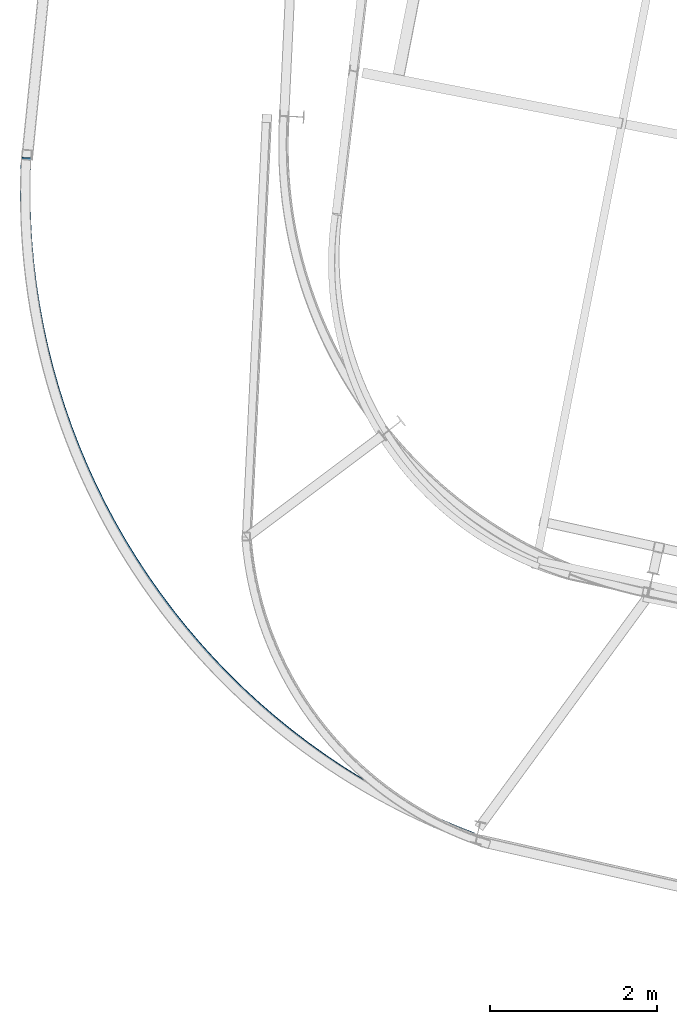
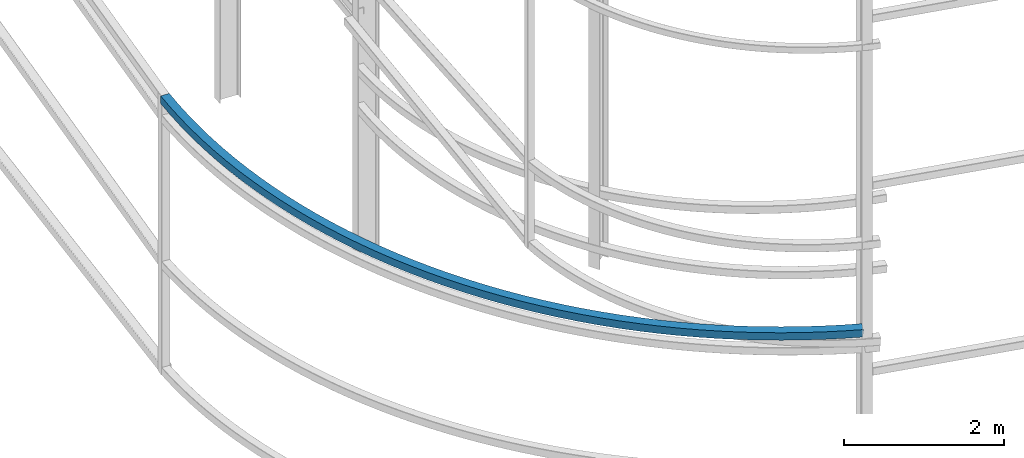
# One storey, part 208 of 215: 1 beam, 1 element without a shape of its own.
"""IFC2X3 building model written with IfcOpenShell, lengths in millimetres."""

import ifcopenshell
import ifcopenshell.guid

model = None  # the IFC model being written
_history = None  # IfcOwnerHistory: only IFC2X3 demands one
_inside = {}  # id of a spatial element -> (the spatial element, [elements in it])
_under = {}  # id of a project, library or spatial element -> (it, [spatial elements below it])
_declared = {}  # id of a project -> (the project, [libraries it declares])
_typed = {}  # id of a type object -> (the type object, [elements of that type])
_made_of = {}  # id of a material, layer set ... -> (it, [elements and type objects made of it])


def new_model(schema):
    """Start an empty IFC model of exactly this schema.

    Asked for "IFC4X3", IfcOpenShell would pick the latest addendum, in which some entities
    have other attributes; the version numbers below select the first issue.
    IFC2X3 requires an IfcOwnerHistory on every rooted entity: one is made here for all.
    """
    global model, _history
    if schema == "IFC4X3":
        model = ifcopenshell.file(schema_version=(4, 3, 0, 0))
    else:
        model = ifcopenshell.file(schema=schema)
    _inside.clear()
    _under.clear()
    _declared.clear()
    _typed.clear()
    _made_of.clear()
    _history = None
    if model.schema == "IFC2X3":
        org = make("IfcOrganization", Name="unknown")
        user = make(
            "IfcPersonAndOrganization",
            ThePerson=make("IfcPerson", FamilyName="unknown"),
            TheOrganization=org,
        )
        app = make(
            "IfcApplication",
            ApplicationDeveloper=org,
            Version="unknown",
            ApplicationFullName="unknown",
            ApplicationIdentifier="unknown",
        )
        _history = make(
            "IfcOwnerHistory",
            OwningUser=user,
            OwningApplication=app,
            ChangeAction="ADDED",
            CreationDate=0,
        )
    return model


def make(cls, **values):
    """One entity of the class cls with the attributes given. An attribute that is None is left unset."""
    return model.create_entity(
        cls, **{name: value for name, value in values.items() if value is not None}
    )


def rooted(cls, **values):
    """An entity with a GlobalId (a new one), such as an element, a storey or a relation."""
    return make(cls, GlobalId=ifcopenshell.guid.new(), OwnerHistory=_history, **values)


def si_unit(unit_type, name, prefix=None):
    """IfcSIUnit, for example si_unit("LENGTHUNIT", "METRE", prefix="MILLI")."""
    return make("IfcSIUnit", UnitType=unit_type, Prefix=prefix, Name=name)


def assignment(units):
    """IfcUnitAssignment: the units of a project."""
    return None if units is None else make("IfcUnitAssignment", Units=units)


def point(xyz):
    """IfcCartesianPoint."""
    return None if xyz is None else make("IfcCartesianPoint", Coordinates=xyz)


def direction(xyz):
    """IfcDirection."""
    return None if xyz is None else make("IfcDirection", DirectionRatios=xyz)


def frame(location, z_axis=None, x_axis=None):
    """IfcAxis2Placement3D, a coordinate frame: its origin and axes. An axis left out is left unset."""
    return make(
        "IfcAxis2Placement3D",
        Location=point(location),
        Axis=direction(z_axis),
        RefDirection=direction(x_axis),
    )


def origin_with_axes():
    """The frame at (0, 0, 0) with the z axis (0, 0, 1) and the x axis (1, 0, 0) written out."""
    return frame((0.0, 0.0, 0.0), z_axis=(0.0, 0.0, 1.0), x_axis=(1.0, 0.0, 0.0))


def place(relative_to, where):
    """IfcLocalPlacement: puts the frame where relative to a parent placement (None: the world)."""
    return make(
        "IfcLocalPlacement", PlacementRelTo=relative_to, RelativePlacement=where
    )


def context(
    kind, dimensions, precision=None, world=None, true_north=None, identifier=None
):
    """IfcGeometricRepresentationContext, for example the 3D "Model" context."""
    return make(
        "IfcGeometricRepresentationContext",
        ContextIdentifier=identifier,
        ContextType=kind,
        CoordinateSpaceDimension=dimensions,
        Precision=precision,
        WorldCoordinateSystem=world,
        TrueNorth=true_north,
    )


def subcontext(parent, identifier, kind, view, scale=None):
    """IfcGeometricRepresentationSubContext, for example "Body" below "Model"."""
    return make(
        "IfcGeometricRepresentationSubContext",
        ContextIdentifier=identifier,
        ContextType=kind,
        ParentContext=parent,
        TargetScale=scale,
        TargetView=view,
    )


def project(units=None, contexts=None):
    """IfcProject with its units and contexts."""
    return rooted(
        "IfcProject",
        Name="project",
        RepresentationContexts=contexts,
        UnitsInContext=assignment(units),
    )


def spatial(cls, under=None, at=None, **own):
    """A site, building, storey or space (cls), placed at a placement, below another one or the project."""
    s = rooted(cls, ObjectPlacement=at, **own)
    if under is not None:
        _under.setdefault(under.id(), (under, []))[1].append(s)
    return s


def faces_of(points, faces, orient=None, outer=None):
    """IfcFace entities. A face is a list of loops; a loop is a list of indices into points, from 0.

    orient and outer hold one flag for each loop. By default every Orientation is true, the
    first loop of a face is its IfcFaceOuterBound and the others are IfcFaceBound.
    """
    made = []
    for i, loops in enumerate(faces):
        bounds = []
        for j, loop in enumerate(loops):
            is_outer = j == 0 if outer is None else outer[i][j]
            bounds.append(
                make(
                    "IfcFaceOuterBound" if is_outer else "IfcFaceBound",
                    Bound=make("IfcPolyLoop", Polygon=[points[k] for k in loop]),
                    Orientation=True if orient is None else orient[i][j],
                )
            )
        made.append(make("IfcFace", Bounds=bounds))
    return made


def faceted_brep(points, faces, orient=None, outer=None, voids=None):
    """IfcFacetedBrep: a solid bounded by flat faces; with voids (closed shells), ...WithVoids."""
    shared = [point(p) for p in points]
    hull = make("IfcClosedShell", CfsFaces=faces_of(shared, faces, orient, outer))
    if voids is None:
        return make("IfcFacetedBrep", Outer=hull)
    return make(
        "IfcFacetedBrepWithVoids",
        Outer=hull,
        Voids=[
            make(cls, CfsFaces=faces_of(shared, fs, o, b)) for cls, fs, o, b in voids
        ],
    )


def shape(context_of_items, identifier, shape_type, items):
    """IfcShapeRepresentation: the items that make up one representation, for example the "Body"."""
    return make(
        "IfcShapeRepresentation",
        ContextOfItems=context_of_items,
        RepresentationIdentifier=identifier,
        RepresentationType=shape_type,
        Items=items,
    )


def material(Name=None, Category=None):
    """IfcMaterial."""
    return make("IfcMaterial", Name=Name, Category=Category)


def made_of(thing, what):
    """Note that an element or type object is made of a material, layer set ...; save() writes the relation."""
    if what is not None:
        _made_of.setdefault(what.id(), (what, []))[1].append(thing)
    return thing


def type_object(cls, material=None, **own):
    """A type object (cls), such as IfcWallType, which elements share."""
    return made_of(rooted(cls, **own), material)


def element(
    cls,
    number,
    at=None,
    inside=None,
    cuts=None,
    type_object=None,
    material=None,
    context=None,
    identifier="Body",
    shape_type=None,
    held_by="IfcProductDefinitionShape",
    body=None,
    shapes=None,
    **own,
):
    """One element of the class cls, such as IfcWall. Its Tag is "e" and its number.

    at: its placement. inside: the storey or other place that contains it. cuts: it is an
    opening in that element (IfcRelVoidsElement). A single representation is given by context,
    identifier, shape_type and body (its items); several are given by shapes. held_by: the class
    of the entity that holds the representations. save() writes the other relations.
    """
    e = rooted(cls, Tag="e%d" % number, ObjectPlacement=at, **own)
    if body is not None:
        shapes = [shape(context, identifier, shape_type, body)]
    if shapes is not None:
        e.Representation = make(held_by, Representations=shapes)
    if inside is not None:
        _inside.setdefault(inside.id(), (inside, []))[1].append(e)
    if cuts is not None:
        rooted(
            "IfcRelVoidsElement", RelatingBuildingElement=cuts, RelatedOpeningElement=e
        )
    if type_object is not None:
        _typed.setdefault(type_object.id(), (type_object, []))[1].append(e)
    return made_of(e, material)


def aggregate(whole, parts):
    """IfcRelAggregates: a whole, such as a stair, and the parts it consists of."""
    return rooted("IfcRelAggregates", RelatingObject=whole, RelatedObjects=parts)


def save(model, path):
    """Write the relations noted so far, then the file.

    IfcRelAggregates (storeys below a building ...), IfcRelContainedInSpatialStructure (elements
    in a storey), IfcRelDefinesByType, IfcRelAssociatesMaterial and IfcRelDeclares: one each for
    every whole, place, type object, material and project.
    """
    for whole, parts in _under.values():
        aggregate(whole, parts)
    for where, things in _inside.values():
        rooted(
            "IfcRelContainedInSpatialStructure",
            RelatedElements=things,
            RelatingStructure=where,
        )
    for kind, things in _typed.values():
        rooted("IfcRelDefinesByType", RelatedObjects=things, RelatingType=kind)
    for what, things in _made_of.values():
        rooted("IfcRelAssociatesMaterial", RelatedObjects=things, RelatingMaterial=what)
    for by, libraries in _declared.values():
        rooted("IfcRelDeclares", RelatingContext=by, RelatedDefinitions=libraries)
    model.write(path)


model = new_model("IFC2X3")

# Units and contexts
model_context = context("Model", 3, precision=1e-05, world=origin_with_axes())
body_context = subcontext(model_context, "Body", "Model", "MODEL_VIEW")
ifc_project = project(units=[si_unit("LENGTHUNIT", "METRE", prefix="MILLI"), si_unit("AREAUNIT", "SQUARE_METRE"), si_unit("VOLUMEUNIT", "CUBIC_METRE"), si_unit("MASSUNIT", "GRAM", prefix="KILO"), si_unit("TIMEUNIT", "SECOND"), si_unit("PLANEANGLEUNIT", "RADIAN"), si_unit("SOLIDANGLEUNIT", "STERADIAN"), si_unit("THERMODYNAMICTEMPERATUREUNIT", "DEGREE_CELSIUS"), si_unit("LUMINOUSINTENSITYUNIT", "LUMEN")], contexts=[model_context])

# Site, building, storey
site_placement = place(None, origin_with_axes())
site = spatial("IfcSite", under=ifc_project, at=site_placement, CompositionType="ELEMENT")
building_placement = place(site_placement, origin_with_axes())
building = spatial("IfcBuilding", under=site, at=building_placement, Name="Undefined", CompositionType="ELEMENT")
storey_placement = place(building_placement, origin_with_axes())
storey = spatial("IfcBuildingStorey", under=building, at=storey_placement, Name="Undefined", CompositionType="ELEMENT", Elevation=0.0)

# Assembly, beam
assembly_placement = place(storey_placement, origin_with_axes())
assembly = element("IfcElementAssembly", 1, at=assembly_placement, inside=storey, Name="Steel Assembly", AssemblyPlace="NOTDEFINED", PredefinedType="RIGID_FRAME")
ifc_material = material(Name="STEEL/S275JR")
beam_type = type_object("IfcBeamType", PredefinedType="NOTDEFINED")
beam_placement = place(assembly_placement, frame((39509.0977958103, 7909.42977064239, 3275.84651972559), z_axis=(0.643150562069678, 0.763305578082692, 0.0610077780066094), x_axis=(-0.76565649122833, 0.642211189191517, 0.0365366380108958)))
beam = element("IfcBeam", 2, at=beam_placement, type_object=beam_type, material=ifc_material, Name="LISSE", context=body_context, shape_type="Brep", body=[
    faceted_brep([(-19.5221315402669, -60.1108239672099, -56.6177995280559), (-20.1975001015489, 59.8872755065345, -56.6177995278413), (223.343370305472, 61.1910041724382, -137.874040640698), (223.959366025851, -58.8074131373819, -137.854231177855), (20.1975001015344, -59.8872755065331, 56.6177995278522), (260.187174768642, -58.6025571844643, -23.4536021911335), (19.5221315402559, 60.1108239672126, 56.6177995280632), (259.571179048256, 61.3958601253557, -23.4734116539767), (18.220656104244, 56.1034357027302, 52.8432795595363), (18.8510000947645, -55.8947904727647, 52.8432795593144), (-18.2206561042549, -56.1034357027302, -52.8432795595181), (-18.851000094779, 55.8947904727652, -52.8432795593144), (224.571497120913, 57.1978854605431, -134.06002602572), (258.38411861418, 57.3890843499321, -27.2861056381043), (258.959047953205, -54.609438472567, -27.2676168061153), (225.146426459934, -54.8006373619573, -134.04153719372), (502.520537815148, -57.4365502622027, -96.1261926602456), (501.964494758246, 62.5621555147927, -96.1639811388923), (469.818652374906, -57.6244409449391, -211.584199702407), (469.262609318012, 62.3742648320572, -211.62198818105), (470.890180454349, -53.6182210629481, -207.736859083612), (470.371206934593, 58.3805709955818, -207.772128330354), (501.41194019857, -53.4428564257278, -99.9760525109305), (500.892966678806, 58.5559356328017, -100.011321757673), (746.96948641734, -56.3903522752603, -161.331566840723), (746.473919414482, 63.6086123284817, -161.385486964678), (717.824305812646, -56.5630208944099, -277.738304777318), (717.328738809789, 63.4359437093322, -277.792224901255), (718.779292932712, -52.5572997869813, -273.859877516905), (718.316763730036, 59.4417338431795, -273.91020296593), (745.981461497089, -52.3961424091085, -165.213588776074), (745.518932294413, 59.6028912210513, -165.263914225099), (993.303926399483, -55.4649479857521, -219.008348412852), (992.86930191646, 64.5342455606815, -219.076537627243), (967.742884318814, -55.6241520760886, -336.254277064265), (967.308259835798, 64.3750414703418, -336.322466278663), (968.580431572067, -51.6188721548647, -332.34835241636), (968.174782054586, 60.3803751551391, -332.411995683124), (992.437404180684, -51.470281670549, -222.918819008384), (992.031754663203, 60.5289656394539, -222.98246227514), (1241.29198881611, -54.6612084554595, -269.102247548042), (1240.91871595498, 65.3381839341077, -269.182829866892), (1219.33914528078, -54.8087182256127, -387.077036823746), (1218.96587241965, 65.1906741639546, -387.157619142574), (1220.05846430326, -50.8038214869553, -383.147229925165), (1219.71007629952, 61.1956114099735, -383.222440089419), (1240.54778493623, -50.6661457014793, -273.037426601186), (1240.19939693249, 61.3332871954503, -273.112636765443), (1490.70024820504, -53.9798902259281, -311.566112010627), (1490.38867831892, 66.0196707200525, -311.657199782589), (1472.37626692201, -54.1174868921157, -430.158745760324), (1472.06469703588, 65.8820740538645, -430.249833532267), (1472.97668063522, -50.1129149717112, -426.208694227735), (1472.68588207485, 61.8866752445392, -426.293709481535), (1490.07906316607, -49.984491416601, -315.522236061348), (1489.78826460568, 62.0150987996467, -315.607251315156), (1741.29394230527, -53.4216346063449, -346.359971541195), (1741.04436866775, 66.5780644506708, -346.459667226332), (1726.61607121686, -53.5511087157652, -465.458852051794), (1726.36649757931, 66.4485903412492, -465.55854773692), (1727.09701446521, -49.5468029435501, -461.492212557616), (1726.86407907018, 62.4529161763294, -461.585261863729), (1740.7963608144, -49.4259604414242, -350.333257414408), (1740.56342541937, 62.5737586784558, -350.426306720503), (1992.83719303338, -52.9869670698895, -373.451075479654), (1992.64985056235, 67.0128395227798, -373.557473435627), (1981.81924808221, -53.1101168153164, -492.944128519612), (1981.63190561117, 66.8896897773525, -493.050526475607), (1982.18026816488, -49.106018270712, -488.964573350157), (1982.00541519192, 62.8938012157769, -489.063878109082), (1992.46368345265, -48.9910785083143, -377.437723846175), (1992.28883047967, 63.0087409781759, -377.537028605089), (2245.09322851013, -52.6762967591217, -392.813923592585), (2244.96829354674, 67.3235866925988, -392.925111868411), (2237.74558063449, -52.7949262863081, -512.588703904887), (2237.62064567111, 67.2049571654125, -512.699892180714), (2237.98633773156, -48.7909758536766, -508.599917503663), (2237.86973176574, 63.2089153679281, -508.70369322777), (2244.8441424155, -48.6802549616373, -396.810122545539), (2244.72753644966, 63.3196362599679, -396.913898269642), (2497.82460592834, -52.4899161008661, -404.430290076249), (2497.76219607101, 67.5100134609611, -404.544352211899), (2494.15417130029, -52.605833810338, -524.374087220396), (2494.09176144296, 67.394095751486, -524.488149356021), (2494.27443879265, -48.6019722346291, -520.379762720102), (2494.21618959247, 63.3979620230734, -520.48622071337), (2497.70017777884, -48.493782372454, -408.432218718906), (2497.64192857867, 63.5061518852499, -408.538676712174), (2750.79343505246, -52.4280005309474, -408.289240711896), (2750.79360904614, 67.5719443486337, -408.404257542192), (2750.80366856771, -52.5430173758109, -528.289185155751), (2750.8038425614, 67.4569275037716, -528.404201986083), (2750.80333325033, -48.5391853183296, -524.293020901976), (2750.80349564442, 63.4607632359462, -524.400369943585), (2750.79378196942, -48.4318362631252, -412.293072754361), (2750.79394436353, 63.5681122911515, -412.400421795999), (3003.76160213905, -52.490608329073, -404.387143158019), (3003.82435981995, 67.5093210614964, -404.501194619224), (3007.45249416505, -52.6065361103892, -524.330312519302), (3007.51525184593, 67.3933932801806, -524.444363980507), (3007.33155635353, -48.6026742046602, -520.336008589304), (3007.39013018904, 63.397259893206, -520.442456619778), (3003.88672379595, -48.4944749420984, -408.389050518763), (3003.94529763145, 63.5054591557678, -408.495498549215), (3256.49099406786, -52.6776805639593, -392.727670369328), (3256.61627636358, 67.3222025454124, -392.838837306332), (3263.85907045277, -52.7963302253506, -512.501195706816), (3263.98435274851, 67.2035528840211, -512.612362643835), (3263.61764398312, -48.7923791329904, -508.512450426813), (3263.73457412582, 63.2075117690888, -508.616206234696), (3256.74077269054, -48.6816394490265, -396.72382677846), (3256.85770283324, 63.3182514530522, -396.827582586368), (3508.74372247216, -52.9890411488122, -373.321797139495), (3508.93141145739, 67.0107649307333, -373.428163112385), (3519.78204781509, -53.1122210718554, -492.812969194041), (3519.96973680033, 66.8875850076906, -492.91933516692), (3519.42035993651, -49.1081215384356, -488.833475658001), (3519.59553632271, 62.8916974691415, -488.932750566), (3509.11792294977, -48.9931536102627, -377.308381740415), (3509.293099336, 63.006665397314, -377.407656648433), (3760.28234765773, -53.4243970070734, -346.187789770935), (3760.53226666512, 66.5753013665303, -346.287442858753), (3774.98053183678, -53.553911309114, -465.284165055957), (3775.23045084416, 66.4457870644906, -465.383818143775), (3774.49892299772, -49.5496042199261, -461.317607649391), (3774.73218073795, 62.4501142621057, -461.410617198013), (3760.78061776394, -49.428724204688, -350.160990716679), (3761.01387550417, 62.5709942773437, -350.254000265322), (4010.8701020992, -53.9833383482792, -311.351188880948), (4011.18201588571, 66.0162217446464, -311.442223481474), (4029.21431005148, -54.12098518426, -429.940695523052), (4029.526223838, 65.8785749086655, -430.031730123595), (4028.61323357929, -50.1164116199625, -425.990746455002), (4028.90435311338, 61.883177800099, -426.075712082169), (4011.49197282383, -49.987941239714, -315.307206922378), (4011.7830923579, 62.0116481803479, -315.392172549517), (4260.271113304, -54.6653390537963, -268.84478536114), (4260.64472827236, 65.3340523138727, -268.925303984528), (4282.2440780483, -54.8129089236904, -386.815828590716), (4282.61769301666, 65.1864824439785, -386.896347214108), (4281.52409972244, -50.808010215771, -382.886144437169), (4281.87280702624, 61.1914217273861, -382.961295152341), (4261.01599929443, -50.6702783372029, -272.779837422913), (4261.36470659823, 61.3291536059537, -272.854988138057), (4508.25062583375, -55.4697571720376, -218.708589511956), (4508.68559030875, 64.5294351846146, -218.776704566793), (4533.83166472346, -55.6290312354963, -335.950156704785), (4534.26662919848, 64.3701611211559, -336.01827175964), (4532.99346224297, -51.6237490214926, -332.044374966856), (4533.39942908632, 60.3754971780504, -332.107949018053), (4509.1178259459, -51.4750932289317, -222.61891225354), (4509.52379278925, 60.5241529706113, -222.682486304744), (4754.57522227398, -56.3958355227237, -160.989793381981), (4755.07112683358, 63.6031277244788, -161.043628952102), (4783.7402564653, -56.5685839225066, -277.391558552863), (4784.23616102488, 63.4303793246954, -277.445394122969), (4782.7846188109, -52.5628602009415, -273.513294232827), (4783.24746306653, 59.436172163114, -273.563540764924), (4755.56392023234, -52.4016283611427, -164.871646740012), (4756.02676448796, 59.5974040029128, -164.921893272112), (4999.01304294478, -57.4427024095899, -95.7427263471473), (4999.56942080538, 62.5560018453816, -95.7804199572529), (5031.73462006147, -57.6306826053783, -211.195153997222), (5032.29099792208, 62.3680216495936, -211.232847607338), (5030.66244675295, -53.6244597903528, -207.34799619588), (5031.18173275616, 58.3743308476205, -207.383176898638), (5000.12230811069, -53.4490116076176, -99.5923970558179), (5000.64159411392, 58.5497790303557, -99.6275777585834), (5241.33400414488, -58.6093724409034, -23.0288039716797), (5241.95033160078, 61.3890431828422, -23.0485083405656), (5277.58132411863, -58.8143275550369, -137.423252191671), (5278.19765157454, 61.1840880687096, -137.442956560579), (5276.39362436804, -54.8075485304403, -133.610760729964), (5276.96886332688, 57.1909727183888, -133.629151474266), (5242.56279239253, -54.6162570905831, -26.8426090579815), (5243.13803135137, 57.3822641582465, -26.8609998022839), (5481.31001472411, -59.8947474569845, 57.0835298008715), (5481.98571164046, 60.10335016822, 57.0836450215065), (5521.04895878593, -60.1184046336989, -56.1452929314728), (5521.72465570228, 59.8796929915056, -56.1451777108305), (5519.74685054776, -56.111012806969, -52.3709949997065), (5520.377501003, 55.8872116432226, -52.3708874604599), (5482.65716942339, -55.9022661087024, 53.3092395504973), (5483.28781987863, 56.0959583414897, 53.3093470897547), (5718.71519078051, -61.2976175638782, 144.51886707242), (5719.44962113929, 58.7001329947957, 144.540613575213), (5761.90835357587, -61.5416863435953, 32.5622187088084), (5762.64278393467, 58.4560642150796, 32.5839652115974), (5760.49306249466, -57.5336256989817, 36.2948318710187), (5761.17853082953, 54.4642748224487, 36.3151286069551), (5720.17944388565, -57.3058281712465, 140.787703677066), (5720.86491222052, 54.6920723501839, 140.808000413002), (5953.32606827948, -62.8166622722051, 239.194906970028), (5954.11854077829, 57.180712478636, 239.240076086568), (5999.93279307722, -63.0828329823671, 128.615784387723), (6000.72526557604, 56.9145417684745, 128.660953504255), (5998.40565133393, -59.0740481336661, 132.303260777688), (5999.14529233282, 52.9235016337848, 132.345418619778), (5954.9060415227, -58.8256221375159, 235.510441854502), (5955.64568252159, 53.171927629935, 235.552599696613), (6184.92181339543, -64.4504517401006, 341.022533113806), (6185.77158209812, 55.5465188153398, 341.092894128524), (6234.89823035693, -64.7403939041133, 231.924991092052), (6235.74799905961, 55.2565766513276, 231.995352106765), (6233.26067541497, -60.7308301467997, 235.563921193272), (6234.05379287081, 51.2663423716144, 235.629591473662), (6186.61601958423, -60.4602174603874, 337.388293746899), (6187.40913704007, 51.5369550580267, 337.453964027289), (6413.28443037757, -66.1974481191005, 449.905897500164), (6414.19069541637, 53.7990902338393, 450.003195984882), (6466.58349785044, -66.5128088848469, 342.392596240501), (6467.48976288924, 53.4837294680924, 342.489894725222), (6464.83707110263, -62.502412247557, 345.979616231973), (6465.68291847217, 49.4943568818535, 346.070428151055), (6415.09127479463, -62.2080755328611, 446.325364074317), (6415.93712216418, 49.7886935965503, 446.416175993407), (6638.19896674433, -68.0560070016709, 565.742510721273), (6639.16087507278, 51.940071548483, 565.868466892294), (6694.77051554161, -68.3984095910896, 459.914619215822), (6695.73242387007, 51.5976689590657, 460.040575386822), (6692.91686085932, -64.3871268864364, 463.446414138369), (6693.81464196588, 47.6092130937077, 463.563973231307), (6640.11674864851, -64.0675511363129, 562.219112876803), (6641.01452975509, 47.9287888438307, 562.336671969722), (6859.4537156131, -70.0243789690635, 688.423338436089), (6860.470361809, 49.9712126108257, 688.579645534792), (6919.24449623643, -70.3954211502432, 584.380439239478), (6920.26114243234, 49.6001704296455, 584.536746338181), (6917.28535842218, -66.3832000248749, 587.853746115987), (6918.23422820503, 45.6126854496893, 587.999632741448), (6861.4806298404, -66.0368939891073, 684.960452032825), (6862.42949962326, 45.9589914854564, 685.10633865829), (7076.84041497515, -72.1007112379966, 817.832904001731), (7077.9108420928, 47.8943666625196, 818.02122670093), (7139.79414773726, -72.5019638212393, 715.672899496407), (7140.8645748549, 47.4931140792778, 715.861222195606), (7137.73137088244, -68.4887528051131, 719.084510403227), (7138.73043619225, 43.506653235369, 719.26027825581), (7078.9745536378, -68.1142503940882, 814.433847941538), (7079.97361894761, 43.8811556463957, 814.609615794114), (7290.15444372781, -74.283049404637, 953.849397169113), (7291.27764419876, 45.7114885909155, 954.071370006041), (7356.21187172725, -74.7160547638855, 853.66841741202), (7357.33507219821, 45.278483231667, 853.89039024894), (7354.0473974763, -70.7018033187264, 857.015182498482), (7355.09571791587, 41.2930988104558, 857.222357146289), (7292.39379801015, -70.2976649834268, 950.517430271761), (7293.4421184497, 41.697237145755, 950.724604919571), (7499.19501427962, -76.5693392842377, 1096.34478874005), (7500.3699308611, 43.4246330889578, 1096.60201457784), (7568.29395917801, -77.0356099052783, 998.237100977636), (7569.46887575949, 42.9583624679176, 998.494326815424), (7566.02982490079, -73.0202684721376, 1001.51593143097), (7567.12641371016, 38.974105742845, 1001.75600887959), (7501.53747632895, -72.5850825591665, 1093.08310667588), (7502.63406513833, 39.409291655817, 1093.32318412451), (7703.76536154713, -78.9574288446956, 1245.18495107824), (7704.99088831713, 41.0359527211608, 1245.47899959722), (7775.84078209612, -79.4584459014891, 1149.24287101487), (7777.06630886613, 40.5349356643678, 1149.53691953383), (7773.47911897015, -75.4419659474001, 1152.4507419676), (7774.6229439555, 36.5518568473985, 1152.72518725198), (7706.20872645776, -74.9743500277259, 1241.99668336011), (7707.35255144309, 37.0194727670732, 1242.27112864448), (7903.67292816524, -81.4450702322033, 1400.22978436056), (7904.9479115636, 38.54769589744, 1400.56219058067), (7978.65698142842, -81.9822821926887, 1306.5435892638), (7979.93196482677, 38.0104839369551, 1306.8759954839), (7976.20001243294, -77.9646162563508, 1309.67754264102), (7977.38999693806, 34.0286321313179, 1309.98778844647), (7906.21489605395, -77.4632184265661, 1397.11799139799), (7907.40488055909, 34.5300299611026, 1397.42823720344), (8098.72954573715, -84.0299218871146, 1561.33334844967), (8100.05278565127, 35.9622047567418, 1561.70561128566), (8176.55165094894, -84.6047431497959, 1469.9911921745), (8177.87489086305, 35.3873834940587, 1470.36345501049), (8174.00168877235, -80.5858448862459, 1473.0483394782), (8175.23671269219, 31.4068066480204, 1473.39578479179), (8101.367723908, -80.049345041075, 1558.30101866838), (8102.60274782786, 31.9433064931904, 1558.64846398195), (8288.75161195278, -86.7095507479867, 1728.3440002643), (8290.12186284736, 33.2819129624409, 1728.7575811148), (8369.33851695462, -87.323360310605, 1639.4318302758), (8370.70876784918, 32.6681033998225, 1639.84541112631), (8366.69796181771, -83.3031845348346, 1642.40935530377), (8367.97686265264, 28.6888482615618, 1642.79536409756), (8291.48351714934, -82.7302956097255, 1725.39404729303), (8292.76241798427, 29.2617371866727, 1725.78005608683), (8473.56026340963, -89.4814345417758, 1901.10453651726), (8474.97623549899, 30.5093434115847, 1901.56085788917), (8556.8361136004, -90.1355747032744, 1814.7060129903), (8558.25208568974, 29.855203250087, 1815.16233436223), (8554.10745099701, -86.1140774327791, 1817.60117448694), (8555.42902494707, 25.8773153236916, 1818.02707443405), (8476.38332415232, -85.5035466153809, 1898.23979644542), (8477.70489810237, 26.4878461410885, 1898.66569639253), (8652.9815439726, -92.3429641579883, 2079.4523416873), (8654.44190443474, 27.6471058601533, 2079.95278585689), (8738.8679537089, -93.0387392550469, 1995.64875875913), (8740.32831417102, 26.951330763095, 1996.14920292873), (8736.05375206641, -89.0158777512074, 1998.45889299573), (8737.41675516441, 22.9748542657258, 1998.92597422067), (8655.89310297922, -88.366487660619, 2076.67557039534), (8657.2561060772, 23.6242443563137, 2077.1426516203), (8826.84656851491, -95.2914461045793, 2263.21954108543), (8828.3499427461, 24.6978944665566, 2263.76544879717), (8915.2626948937, -96.0301212838717, 2182.08975033533), (8916.76606912488, 23.9592192872642, 2182.63565804709), (8912.36560315543, -92.0058540921905, 2184.81227361741), (8913.76875243789, 19.9841971075361, 2185.32178748168), (8829.8438852019, -91.3164239248526, 2260.53341165082), (8831.24703448434, 20.6736272748753, 2261.0429255151), (8994.99168188594, -98.3241050432762, 2452.23315887141), (8996.53665479456, 21.6644852556797, 2452.82582807599), (9085.85430084003, -99.1069050706124, 2373.8534950996), (9087.39927374865, 20.8816852283439, 2374.44616430418), (9082.87704597185, -95.0811920597357, 2376.48590619882), (9084.31902068657, 16.9081588859549, 2377.03906412311), (8998.07193494802, -94.3505787008889, 2449.6402590525), (8999.51390966274, 17.6387722448021, 2450.19341697678), (9157.25861295589, -101.438086401936, 2646.31528087202), (9158.84373029444, 18.5497335058785, 2646.95596550462), (9250.48219759087, -102.266194509423, 2570.75949024738), (9252.06731492944, 17.7216253983911, 2571.40017487999), (9247.42758201434, -98.2389969089136, 2573.29937275595), (9248.90702486366, 13.7496350050455, 2573.89734507973), (9160.41890302169, -97.4660960085912, 2643.81811067228), (9161.898345871, 14.5225359053675, 2644.41608299605), (9313.49462359282, -104.63045906149, 2845.28322204743), (9315.11839332682, 15.3565710613702, 2845.97313084744), (9408.9914246916, -105.50501583378, 2772.62239269201), (9410.61519442562, 14.4820142890781, 2773.31230149205), (9316.7319759539, -100.660043283138, 2842.88419136226), (9318.24749437231, 11.3278514981976, 2843.52810624228), (9407.37784206452, 10.5115985107263, 2775.71133217723), (9405.86232364611, -101.476296270609, 2775.06741729721)], [[[0, 1, 2, 3]], [[4, 0, 3, 5]], [[6, 4, 5, 7]], [[1, 6, 7, 2]], [[0, 4, 6, 1], [8, 9, 10, 11]], [[8, 11, 12, 13]], [[9, 8, 13, 14]], [[10, 9, 14, 15]], [[11, 10, 15, 12]], [[5, 16, 17, 7]], [[3, 18, 16, 5]], [[2, 19, 18, 3]], [[7, 17, 19, 2]], [[15, 20, 21, 12]], [[14, 22, 20, 15]], [[13, 23, 22, 14]], [[12, 21, 23, 13]], [[16, 24, 25, 17]], [[18, 26, 24, 16]], [[19, 27, 26, 18]], [[17, 25, 27, 19]], [[20, 28, 29, 21]], [[22, 30, 28, 20]], [[23, 31, 30, 22]], [[21, 29, 31, 23]], [[24, 32, 33, 25]], [[26, 34, 32, 24]], [[27, 35, 34, 26]], [[25, 33, 35, 27]], [[28, 36, 37, 29]], [[30, 38, 36, 28]], [[31, 39, 38, 30]], [[29, 37, 39, 31]], [[32, 40, 41, 33]], [[34, 42, 40, 32]], [[35, 43, 42, 34]], [[33, 41, 43, 35]], [[36, 44, 45, 37]], [[38, 46, 44, 36]], [[39, 47, 46, 38]], [[37, 45, 47, 39]], [[40, 48, 49, 41]], [[42, 50, 48, 40]], [[43, 51, 50, 42]], [[41, 49, 51, 43]], [[44, 52, 53, 45]], [[46, 54, 52, 44]], [[47, 55, 54, 46]], [[45, 53, 55, 47]], [[48, 56, 57, 49]], [[50, 58, 56, 48]], [[51, 59, 58, 50]], [[49, 57, 59, 51]], [[52, 60, 61, 53]], [[54, 62, 60, 52]], [[55, 63, 62, 54]], [[53, 61, 63, 55]], [[56, 64, 65, 57]], [[58, 66, 64, 56]], [[59, 67, 66, 58]], [[57, 65, 67, 59]], [[60, 68, 69, 61]], [[62, 70, 68, 60]], [[63, 71, 70, 62]], [[61, 69, 71, 63]], [[64, 72, 73, 65]], [[66, 74, 72, 64]], [[67, 75, 74, 66]], [[65, 73, 75, 67]], [[68, 76, 77, 69]], [[70, 78, 76, 68]], [[71, 79, 78, 70]], [[69, 77, 79, 71]], [[72, 80, 81, 73]], [[74, 82, 80, 72]], [[75, 83, 82, 74]], [[73, 81, 83, 75]], [[76, 84, 85, 77]], [[78, 86, 84, 76]], [[79, 87, 86, 78]], [[77, 85, 87, 79]], [[80, 88, 89, 81]], [[82, 90, 88, 80]], [[83, 91, 90, 82]], [[81, 89, 91, 83]], [[84, 92, 93, 85]], [[86, 94, 92, 84]], [[87, 95, 94, 86]], [[85, 93, 95, 87]], [[88, 96, 97, 89]], [[90, 98, 96, 88]], [[91, 99, 98, 90]], [[89, 97, 99, 91]], [[92, 100, 101, 93]], [[94, 102, 100, 92]], [[95, 103, 102, 94]], [[93, 101, 103, 95]], [[96, 104, 105, 97]], [[98, 106, 104, 96]], [[99, 107, 106, 98]], [[97, 105, 107, 99]], [[100, 108, 109, 101]], [[102, 110, 108, 100]], [[103, 111, 110, 102]], [[101, 109, 111, 103]], [[104, 112, 113, 105]], [[106, 114, 112, 104]], [[107, 115, 114, 106]], [[105, 113, 115, 107]], [[108, 116, 117, 109]], [[110, 118, 116, 108]], [[111, 119, 118, 110]], [[109, 117, 119, 111]], [[112, 120, 121, 113]], [[114, 122, 120, 112]], [[115, 123, 122, 114]], [[113, 121, 123, 115]], [[116, 124, 125, 117]], [[118, 126, 124, 116]], [[119, 127, 126, 118]], [[117, 125, 127, 119]], [[120, 128, 129, 121]], [[122, 130, 128, 120]], [[123, 131, 130, 122]], [[121, 129, 131, 123]], [[124, 132, 133, 125]], [[126, 134, 132, 124]], [[127, 135, 134, 126]], [[125, 133, 135, 127]], [[128, 136, 137, 129]], [[130, 138, 136, 128]], [[131, 139, 138, 130]], [[129, 137, 139, 131]], [[132, 140, 141, 133]], [[134, 142, 140, 132]], [[135, 143, 142, 134]], [[133, 141, 143, 135]], [[136, 144, 145, 137]], [[138, 146, 144, 136]], [[139, 147, 146, 138]], [[137, 145, 147, 139]], [[140, 148, 149, 141]], [[142, 150, 148, 140]], [[143, 151, 150, 142]], [[141, 149, 151, 143]], [[144, 152, 153, 145]], [[146, 154, 152, 144]], [[147, 155, 154, 146]], [[145, 153, 155, 147]], [[148, 156, 157, 149]], [[150, 158, 156, 148]], [[151, 159, 158, 150]], [[149, 157, 159, 151]], [[152, 160, 161, 153]], [[154, 162, 160, 152]], [[155, 163, 162, 154]], [[153, 161, 163, 155]], [[156, 164, 165, 157]], [[158, 166, 164, 156]], [[159, 167, 166, 158]], [[157, 165, 167, 159]], [[160, 168, 169, 161]], [[162, 170, 168, 160]], [[163, 171, 170, 162]], [[161, 169, 171, 163]], [[164, 172, 173, 165]], [[166, 174, 172, 164]], [[167, 175, 174, 166]], [[165, 173, 175, 167]], [[168, 176, 177, 169]], [[170, 178, 176, 168]], [[171, 179, 178, 170]], [[169, 177, 179, 171]], [[172, 180, 181, 173]], [[174, 182, 180, 172]], [[175, 183, 182, 174]], [[173, 181, 183, 175]], [[176, 184, 185, 177]], [[178, 186, 184, 176]], [[179, 187, 186, 178]], [[177, 185, 187, 179]], [[180, 188, 189, 181]], [[182, 190, 188, 180]], [[183, 191, 190, 182]], [[181, 189, 191, 183]], [[184, 192, 193, 185]], [[186, 194, 192, 184]], [[187, 195, 194, 186]], [[185, 193, 195, 187]], [[188, 196, 197, 189]], [[190, 198, 196, 188]], [[191, 199, 198, 190]], [[189, 197, 199, 191]], [[192, 200, 201, 193]], [[194, 202, 200, 192]], [[195, 203, 202, 194]], [[193, 201, 203, 195]], [[196, 204, 205, 197]], [[198, 206, 204, 196]], [[199, 207, 206, 198]], [[197, 205, 207, 199]], [[200, 208, 209, 201]], [[202, 210, 208, 200]], [[203, 211, 210, 202]], [[201, 209, 211, 203]], [[204, 212, 213, 205]], [[206, 214, 212, 204]], [[207, 215, 214, 206]], [[205, 213, 215, 207]], [[208, 216, 217, 209]], [[210, 218, 216, 208]], [[211, 219, 218, 210]], [[209, 217, 219, 211]], [[212, 220, 221, 213]], [[214, 222, 220, 212]], [[215, 223, 222, 214]], [[213, 221, 223, 215]], [[216, 224, 225, 217]], [[218, 226, 224, 216]], [[219, 227, 226, 218]], [[217, 225, 227, 219]], [[220, 228, 229, 221]], [[222, 230, 228, 220]], [[223, 231, 230, 222]], [[221, 229, 231, 223]], [[224, 232, 233, 225]], [[226, 234, 232, 224]], [[227, 235, 234, 226]], [[225, 233, 235, 227]], [[228, 236, 237, 229]], [[230, 238, 236, 228]], [[231, 239, 238, 230]], [[229, 237, 239, 231]], [[232, 240, 241, 233]], [[234, 242, 240, 232]], [[235, 243, 242, 234]], [[233, 241, 243, 235]], [[236, 244, 245, 237]], [[238, 246, 244, 236]], [[239, 247, 246, 238]], [[237, 245, 247, 239]], [[240, 248, 249, 241]], [[242, 250, 248, 240]], [[243, 251, 250, 242]], [[241, 249, 251, 243]], [[244, 252, 253, 245]], [[246, 254, 252, 244]], [[247, 255, 254, 246]], [[245, 253, 255, 247]], [[248, 256, 257, 249]], [[250, 258, 256, 248]], [[251, 259, 258, 250]], [[249, 257, 259, 251]], [[252, 260, 261, 253]], [[254, 262, 260, 252]], [[255, 263, 262, 254]], [[253, 261, 263, 255]], [[256, 264, 265, 257]], [[258, 266, 264, 256]], [[259, 267, 266, 258]], [[257, 265, 267, 259]], [[260, 268, 269, 261]], [[262, 270, 268, 260]], [[263, 271, 270, 262]], [[261, 269, 271, 263]], [[264, 272, 273, 265]], [[266, 274, 272, 264]], [[267, 275, 274, 266]], [[265, 273, 275, 267]], [[268, 276, 277, 269]], [[270, 278, 276, 268]], [[271, 279, 278, 270]], [[269, 277, 279, 271]], [[272, 280, 281, 273]], [[274, 282, 280, 272]], [[275, 283, 282, 274]], [[273, 281, 283, 275]], [[276, 284, 285, 277]], [[278, 286, 284, 276]], [[279, 287, 286, 278]], [[277, 285, 287, 279]], [[280, 288, 289, 281]], [[282, 290, 288, 280]], [[283, 291, 290, 282]], [[281, 289, 291, 283]], [[284, 292, 293, 285]], [[286, 294, 292, 284]], [[287, 295, 294, 286]], [[285, 293, 295, 287]], [[288, 296, 297, 289]], [[290, 298, 296, 288]], [[291, 299, 298, 290]], [[289, 297, 299, 291]], [[292, 300, 301, 293]], [[294, 302, 300, 292]], [[295, 303, 302, 294]], [[293, 301, 303, 295]], [[296, 304, 305, 297]], [[298, 306, 304, 296]], [[299, 307, 306, 298]], [[297, 305, 307, 299]], [[300, 308, 309, 301]], [[302, 310, 308, 300]], [[303, 311, 310, 302]], [[301, 309, 311, 303]], [[304, 312, 313, 305]], [[306, 314, 312, 304]], [[307, 315, 314, 306]], [[305, 313, 315, 307]], [[308, 316, 317, 309]], [[310, 318, 316, 308]], [[311, 319, 318, 310]], [[309, 317, 319, 311]], [[312, 320, 321, 313]], [[314, 322, 320, 312]], [[315, 323, 322, 314]], [[313, 321, 323, 315]], [[316, 324, 325, 317]], [[318, 326, 324, 316]], [[319, 327, 326, 318]], [[317, 325, 327, 319]], [[320, 328, 329, 321]], [[322, 330, 328, 320]], [[323, 331, 330, 322]], [[321, 329, 331, 323]], [[328, 330, 331, 329], [332, 333, 334, 335]], [[324, 335, 334, 325]], [[326, 332, 335, 324]], [[327, 333, 332, 326]], [[325, 334, 333, 327]]]),
])
aggregate(assembly, [beam])

save(model, "model.ifc")
